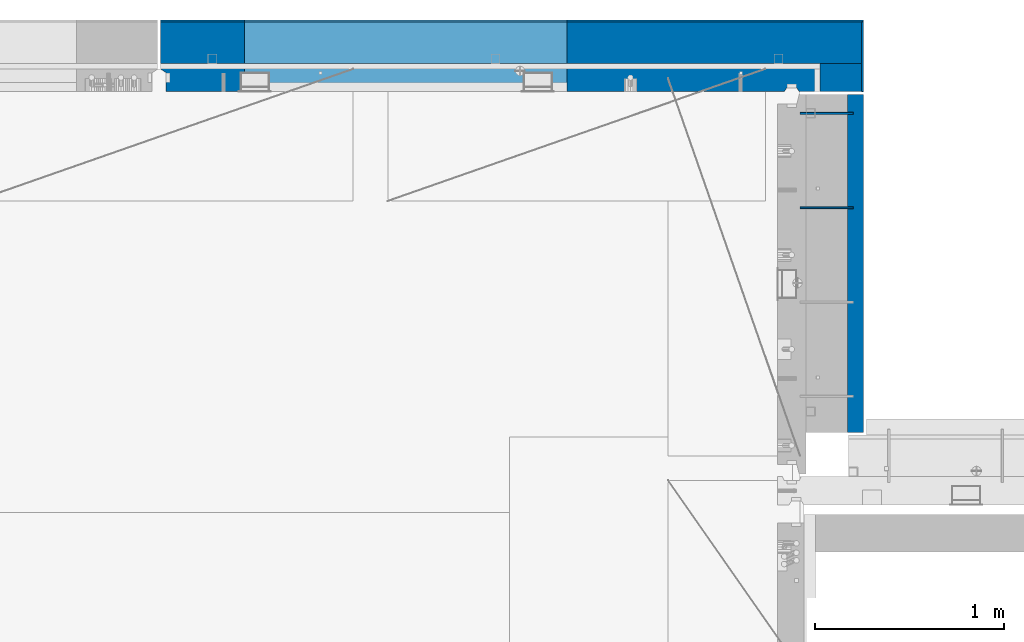
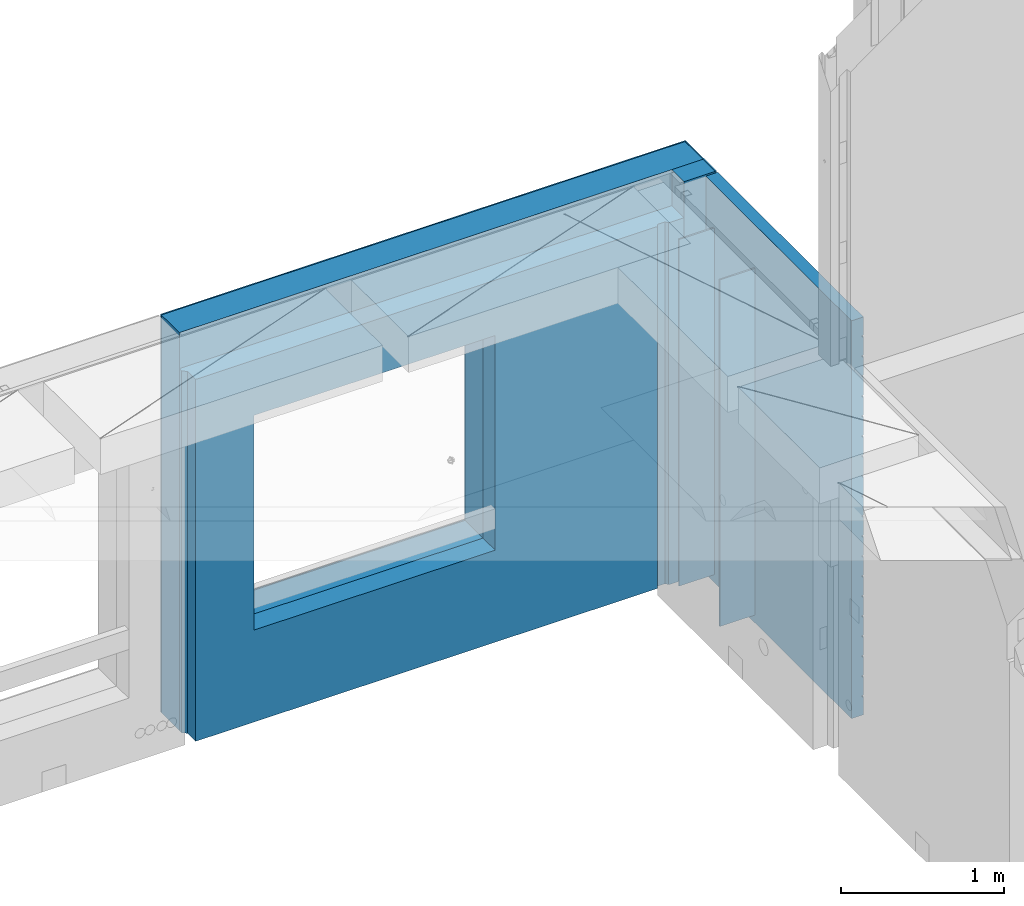
# One storey, part 239 of 352: 8 walls, 2 elements without a shape of their own.
"""IFC2X3 building model written with IfcOpenShell, lengths in millimetres."""

from ifc_helpers import new_model, si_unit, frame, origin_with_axes, place, context, subcontext, project, spatial, faceted_brep, material, type_object, element, aggregate, save


model = new_model("IFC2X3")

# Units and contexts
model_context = context("Model", 3, precision=1e-05, world=origin_with_axes())
body_context = subcontext(model_context, "Body", "Model", "MODEL_VIEW")
ifc_project = project(units=[si_unit("LENGTHUNIT", "METRE", prefix="MILLI"), si_unit("AREAUNIT", "SQUARE_METRE"), si_unit("VOLUMEUNIT", "CUBIC_METRE"), si_unit("MASSUNIT", "GRAM", prefix="KILO"), si_unit("TIMEUNIT", "SECOND"), si_unit("PLANEANGLEUNIT", "RADIAN"), si_unit("SOLIDANGLEUNIT", "STERADIAN"), si_unit("THERMODYNAMICTEMPERATUREUNIT", "DEGREE_CELSIUS"), si_unit("LUMINOUSINTENSITYUNIT", "LUMEN")], contexts=[model_context])

# Site, building, storey
site_placement = place(None, origin_with_axes())
site = spatial("IfcSite", under=ifc_project, at=site_placement, CompositionType="ELEMENT")
building_placement = place(site_placement, origin_with_axes())
building = spatial("IfcBuilding", under=site, at=building_placement, CompositionType="ELEMENT")
storey_placement = place(building_placement, origin_with_axes())
storey = spatial("IfcBuildingStorey", under=building, at=storey_placement, Name="6", CompositionType="ELEMENT", Elevation=0.0)

# Assembly, walls
assembly_1_placement = place(storey_placement, origin_with_axes())
assembly_1 = element("IfcElementAssembly", 1, at=assembly_1_placement, inside=storey, AssemblyPlace="NOTDEFINED", PredefinedType="REINFORCEMENT_UNIT")
ifc_material_1 = material(Name="Undefined")
wall_type_1 = type_object("IfcWallType", PredefinedType="NOTDEFINED")
wall_1_placement = place(assembly_1_placement, frame((17730.0, 22005.0, 98115.0), z_axis=(0.0, 0.0, 1.0), x_axis=(1.0, 0.0, 0.0)))
wall_1 = element("IfcWall", 2, at=wall_1_placement, type_object=wall_type_1, material=ifc_material_1, Name="(PD)", context=body_context, shape_type="Brep", body=[
    faceted_brep([(0.0, 5.0, -1300.0), (0.0, 5.0, 1300.0), (280.0, 5.0, 1300.0), (280.0, 5.0, -1300.0), (0.0, -5.0, 1300.0), (280.0, -5.0, 1300.0), (0.0, -5.0, -1300.0), (280.0, -5.0, -1300.0)], [[[0, 1, 2, 3]], [[1, 4, 5, 2]], [[4, 6, 7, 5]], [[6, 0, 3, 7]], [[5, 7, 3, 2]], [[6, 4, 1, 0]]]),
])
wall_2_placement = place(assembly_1_placement, frame((17730.0, 22505.0, 98115.0), z_axis=(0.0, 0.0, 1.0), x_axis=(1.0, 0.0, 0.0)))
wall_2 = element("IfcWall", 3, at=wall_2_placement, type_object=wall_type_1, material=ifc_material_1, Name="(PD)", context=body_context, shape_type="Brep", body=[
    faceted_brep([(0.0, 5.0, -1300.0), (0.0, 5.0, 1300.0), (280.0, 5.0, 1300.0), (280.0, 5.0, -1300.0), (0.0, -5.0, 1300.0), (280.0, -5.0, 1300.0), (0.0, -5.0, -1300.0), (280.0, -5.0, -1300.0)], [[[0, 1, 2, 3]], [[1, 4, 5, 2]], [[4, 6, 7, 5]], [[6, 0, 3, 7]], [[5, 7, 3, 2]], [[6, 4, 1, 0]]]),
])

assembly_2_placement = place(storey_placement, origin_with_axes())
assembly_2 = element("IfcElementAssembly", 4, at=assembly_2_placement, inside=storey, AssemblyPlace="NOTDEFINED", PredefinedType="REINFORCEMENT_UNIT")
ifc_material_2 = material()
wall_type_2 = type_object("IfcWallType", PredefinedType="NOTDEFINED")
wall_3_placement = place(assembly_2_placement, frame((17945.0, 22770.0, 98247.5), z_axis=(0.0, 0.0, 1.0), x_axis=(0.0, -1.0, 0.0)))
wall_3 = element("IfcWall", 5, at=wall_3_placement, type_object=wall_type_2, material=ifc_material_2, context=body_context, shape_type="Brep", body=[
    faceted_brep([(0.0, 110.0, -1492.5), (0.0, 110.0, 1492.5), (150.0, 110.0, 1492.5), (150.0, 110.0, -1492.5), (0.0, -110.0, 1492.5), (150.0, -110.0, 1492.5), (0.0, -110.0, -1492.5), (150.0, -110.0, -1492.5)], [[[0, 1, 2, 3]], [[1, 4, 5, 2]], [[4, 6, 7, 5]], [[6, 0, 3, 7]], [[5, 7, 3, 2]], [[6, 4, 1, 0]]]),
])
wall_4_placement = place(assembly_2_placement, frame((14340.0, 22880.0, 98247.5), z_axis=(0.0, 0.0, 1.0), x_axis=(1.0, 0.0, 0.0)))
wall_4 = element("IfcWall", 6, at=wall_4_placement, type_object=wall_type_2, material=ifc_material_2, context=body_context, shape_type="Brep", body=[
    faceted_brep([(0.0, -110.0, -1492.5), (0.0, 110.0, -1492.5), (3715.0, 110.0, -1492.5), (3715.0, -110.0, -1492.5), (0.0, -110.0, 1492.5), (0.0, 110.0, 1492.5), (3715.0, -110.0, 1492.5), (3715.0, 110.0, 1492.5), (444.999710731721, 110.0, -802.5), (2154.99971073172, 110.0, -802.5), (2154.99971073172, 110.0, 807.5), (444.999710731721, 110.0, 807.5), (444.999710731721, -110.0, -802.5), (444.999710731721, -110.0, 807.5), (2154.99971073172, -110.0, 807.5), (2154.99971073172, -110.0, -802.5)], [[[0, 1, 2, 3]], [[0, 4, 5, 1]], [[5, 4, 6, 7]], [[1, 5, 7, 2], [8, 9, 10, 11]], [[6, 3, 2, 7]], [[4, 0, 3, 6], [12, 13, 14, 15]], [[10, 14, 13, 11]], [[9, 15, 14, 10]], [[8, 12, 15, 9]], [[11, 13, 12, 8]]]),
])

# Wall
ifc_material_3 = material(Name="CONCRETE/C30/37")
wall_type_3 = type_object("IfcWallType", PredefinedType="NOTDEFINED")
wall_5_placement = place(assembly_1_placement, frame((18022.5, 22620.0, 98247.5), z_axis=(0.0, 0.0, 1.0), x_axis=(0.0, -1.0, 0.0)))
wall_5 = element("IfcWall", 7, at=wall_5_placement, type_object=wall_type_3, material=ifc_material_3, context=body_context, shape_type="Brep", body=[
    faceted_brep([(15.0, 42.5, 1342.99999994476), (15.0, 32.4999992506928, 1344.9999999992), (1805.0, 32.5, 1345.0), (1805.0, 42.5, 1343.0), (15.0, 32.4999991126933, 1355.00000040043), (1805.0, 32.5, 1355.0), (15.0, 42.5, 1356.99999988925), (1805.0, 42.5, 1357.0), (15.0, 42.5, 1206.99999988925), (1805.0, 42.5, 1207.0), (1805.0, 32.5, 1205.0), (15.0000000000009, 32.4999991126933, 1205.00000040043), (1805.0, 32.5, 1195.0), (15.0000000000009, 32.4999992506928, 1194.9999999992), (15.0, 42.5, 1192.99999994476), (1805.0, 42.5, 1193.0), (1805.0, 42.5, 1057.0), (15.0, 42.5, 1056.99999988925), (1805.0, 32.5, 1055.0), (15.0, 32.4999991126933, 1055.00000040043), (1805.0, 32.5, 1045.0), (15.0, 32.4999992506928, 1044.9999999992), (15.0, 42.5, 1042.99999994476), (1805.0, 42.5, 1043.0), (1805.0, 42.5, 907.0), (15.0, 42.5, 906.999999889245), (1805.0, 32.5, 905.0), (15.0, 32.4999991126933, 905.000000400425), (1805.0, 32.5, 895.0), (15.0, 32.4999992506928, 894.9999999992), (15.0, 42.5, 892.999999944761), (1805.0, 42.5, 893.0), (1805.0, 42.5, 757.0), (15.0, 42.5, 756.999999889245), (1805.0, 32.5, 755.0), (15.0, 32.4999991126933, 755.000000400425), (1805.0, 32.5, 745.0), (15.0, 32.4999992506928, 744.9999999992), (15.0, 42.5, 742.999999944761), (1805.0, 42.5, 743.0), (1805.0, 42.5, 607.0), (15.0, 42.5, 606.999999889245), (1805.0, 32.5, 605.0), (15.0, 32.4999991126933, 605.000000400425), (1805.0, 32.5, 595.0), (15.0, 32.4999992506928, 594.9999999992), (15.0, 42.5, 592.999999944761), (1805.0, 42.5, 593.0), (1805.0, 42.5, 457.0), (15.0, 42.5, 456.999999889245), (1805.0, 32.5, 455.0), (15.0, 32.4999991126933, 455.000000400425), (1805.0, 32.5, 445.0), (15.0, 32.4999992506928, 444.9999999992), (15.0, 42.5, 442.999999944761), (1805.0, 42.5, 443.0), (1805.0, 42.5, 307.0), (15.0, 42.5, 306.999999889245), (1805.0, 32.5, 305.0), (15.0, 32.4999991126933, 305.000000400425), (1805.0, 32.5, 295.0), (15.0, 32.4999992506928, 294.9999999992), (15.0, 42.5, 292.999999944761), (1805.0, 42.5, 293.0), (1805.0, 42.5, 157.0), (15.0, 42.5, 156.999999889245), (1805.0, 32.5, 155.0), (15.0000000000009, 32.4999991126933, 155.000000400425), (1805.0, 32.5, 145.0), (15.0000000000009, 32.4999992506928, 144.9999999992), (15.0, 42.5, 142.999999944761), (1805.0, 42.5, 143.0), (1805.0, 42.5, 7.0), (15.0, 42.5, 6.99999988924537), (1805.0, 32.5, 5.0), (14.9999999999991, 32.4999991126933, 5.00000040042505), (1805.0, 32.5, -5.0), (14.9999999999991, 32.4999992506928, -5.00000000080036), (15.0, 42.5, -7.00000005523907), (1805.0, 42.5, -7.0), (1805.0, 42.5, -143.0), (15.0, 42.5, -143.000000110755), (1805.0, 32.5, -145.0), (15.0000000000009, 32.4999991126933, -144.999999599575), (1805.0, 32.5, -155.0), (15.0000000000009, 32.4999992506928, -155.0000000008), (15.0, 42.5, -157.000000055239), (1805.0, 42.5, -157.0), (1805.0, 42.5, -293.0), (15.0, 42.5, -293.000000110755), (1805.0, 32.5, -295.0), (15.0, 32.4999991126933, -294.999999599575), (1805.0, 32.5, -305.0), (15.0, 32.4999992506928, -305.0000000008), (15.0, 42.5, -307.000000055239), (1805.0, 42.5, -307.0), (1805.0, 42.5, -443.0), (15.0, 42.5, -443.000000110755), (1805.0, 32.5, -445.0), (15.0000000000009, 32.4999991126933, -444.999999599575), (1805.0, 32.5, -455.0), (15.0000000000009, 32.4999992506928, -455.0000000008), (15.0, 42.5, -457.000000055239), (1805.0, 42.5, -457.0), (1805.0, 42.5, -593.0), (15.0, 42.5, -593.000000110755), (1805.0, 32.5, -595.0), (15.0, 32.4999991126933, -594.999999599575), (1805.0, 32.5, -605.0), (15.0, 32.4999992506928, -605.0000000008), (15.0, 42.5, -607.000000055239), (1805.0, 42.5, -607.0), (1805.0, 42.5, -743.0), (15.0, 42.5, -743.000000110755), (1805.0, 32.5, -745.0), (15.0, 32.4999991126933, -744.999999599575), (1805.0, 32.5, -755.0), (15.0, 32.4999992506928, -755.0000000008), (15.0, 42.5, -757.000000055239), (1805.0, 42.5, -757.0), (1805.0, 42.5, -893.0), (15.0, 42.5, -893.000000110755), (1805.0, 32.5, -895.0), (15.0000000000009, 32.4999991126933, -894.999999599575), (1805.0, 32.5, -905.0), (15.0000000000009, 32.4999992506928, -905.0000000008), (15.0, 42.5, -907.000000055239), (1805.0, 42.5, -907.0), (1805.0, 42.5, -1043.0), (15.0, 42.5, -1043.00000011075), (1805.0, 32.5, -1045.0), (15.0, 32.4999991126933, -1044.99999959957), (1805.0, 32.5, -1055.0), (15.0, 32.4999992506928, -1055.0000000008), (15.0, 42.5, -1057.00000005524), (1805.0, 42.5, -1057.0), (1805.0, 42.5, -1193.0), (15.0, 42.5, -1193.00000011075), (1805.0, 32.5, -1195.0), (15.0, 32.4999991126933, -1194.99999959957), (1805.0, 32.5, -1205.0), (15.0, 32.4999992506928, -1205.0000000008), (15.0, 42.5, -1207.00000005524), (1805.0, 42.5, -1207.0), (1805.0, 42.5, -1343.0), (15.0, 42.5, -1343.00000011075), (1805.0, 32.5, -1345.0), (15.0, 32.4999991126933, -1344.99999959957), (1805.0, 32.5, -1355.0), (15.0, 32.4999992506928, -1355.0000000008), (15.0, 42.5, -1357.00000005524), (1805.0, 42.5, -1357.0), (1805.0, 42.5, -1492.5), (15.0, 42.5, -1492.5), (15.0, -42.5, -1492.5), (1805.0, -42.5, -1492.5), (15.0, -42.5, 1492.5), (1805.0, -42.5, 1492.5), (15.0, 42.5, 1492.5), (1805.0, 42.5, 1492.5)], [[[0, 1, 2, 3]], [[4, 5, 2, 1]], [[6, 7, 5, 4]], [[8, 9, 10, 11]], [[11, 10, 12, 13]], [[14, 13, 12, 15]], [[16, 17, 14, 15]], [[17, 16, 18, 19]], [[19, 18, 20, 21]], [[22, 21, 20, 23]], [[24, 25, 22, 23]], [[25, 24, 26, 27]], [[27, 26, 28, 29]], [[30, 29, 28, 31]], [[32, 33, 30, 31]], [[33, 32, 34, 35]], [[35, 34, 36, 37]], [[38, 37, 36, 39]], [[40, 41, 38, 39]], [[41, 40, 42, 43]], [[43, 42, 44, 45]], [[46, 45, 44, 47]], [[48, 49, 46, 47]], [[49, 48, 50, 51]], [[51, 50, 52, 53]], [[54, 53, 52, 55]], [[56, 57, 54, 55]], [[57, 56, 58, 59]], [[59, 58, 60, 61]], [[62, 61, 60, 63]], [[64, 65, 62, 63]], [[65, 64, 66, 67]], [[67, 66, 68, 69]], [[70, 69, 68, 71]], [[72, 73, 70, 71]], [[73, 72, 74, 75]], [[75, 74, 76, 77]], [[78, 77, 76, 79]], [[80, 81, 78, 79]], [[81, 80, 82, 83]], [[83, 82, 84, 85]], [[86, 85, 84, 87]], [[88, 89, 86, 87]], [[89, 88, 90, 91]], [[91, 90, 92, 93]], [[94, 93, 92, 95]], [[96, 97, 94, 95]], [[97, 96, 98, 99]], [[99, 98, 100, 101]], [[102, 101, 100, 103]], [[104, 105, 102, 103]], [[105, 104, 106, 107]], [[107, 106, 108, 109]], [[110, 109, 108, 111]], [[112, 113, 110, 111]], [[113, 112, 114, 115]], [[115, 114, 116, 117]], [[118, 117, 116, 119]], [[120, 121, 118, 119]], [[121, 120, 122, 123]], [[123, 122, 124, 125]], [[126, 125, 124, 127]], [[128, 129, 126, 127]], [[129, 128, 130, 131]], [[131, 130, 132, 133]], [[134, 133, 132, 135]], [[136, 137, 134, 135]], [[137, 136, 138, 139]], [[139, 138, 140, 141]], [[142, 141, 140, 143]], [[144, 145, 142, 143]], [[145, 144, 146, 147]], [[147, 146, 148, 149]], [[150, 149, 148, 151]], [[152, 153, 150, 151]], [[154, 153, 152, 155]], [[156, 154, 155, 157]], [[158, 156, 157, 159]], [[1, 0, 8, 11, 13, 14, 17, 19, 21, 22, 25, 27, 29, 30, 33, 35, 37, 38, 41, 43, 45, 46, 49, 51, 53, 54, 57, 59, 61, 62, 65, 67, 69, 70, 73, 75, 77, 78, 81, 83, 85, 86, 89, 91, 93, 94, 97, 99, 101, 102, 105, 107, 109, 110, 113, 115, 117, 118, 121, 123, 125, 126, 129, 131, 133, 134, 137, 139, 141, 142, 145, 147, 149, 150, 153, 154, 156, 158, 6, 4]], [[9, 8, 0, 3]], [[159, 157, 155, 152, 151, 148, 146, 144, 143, 140, 138, 136, 135, 132, 130, 128, 127, 124, 122, 120, 119, 116, 114, 112, 111, 108, 106, 104, 103, 100, 98, 96, 95, 92, 90, 88, 87, 84, 82, 80, 79, 76, 74, 72, 71, 68, 66, 64, 63, 60, 58, 56, 55, 52, 50, 48, 47, 44, 42, 40, 39, 36, 34, 32, 31, 28, 26, 24, 23, 20, 18, 16, 15, 12, 10, 9, 3, 2, 5, 7]], [[158, 159, 7, 6]]]),
])

aggregate(assembly_1, [wall_1, wall_2, wall_5])

ifc_material_4 = material(Name="CONCRETE/C25/30")
wall_type_4 = type_object("IfcWallType", PredefinedType="NOTDEFINED")
wall_6_placement = place(assembly_2_placement, frame((14340.0, 22695.0, 98112.5), z_axis=(0.0, 0.0, 1.0), x_axis=(1.0, 0.0, 0.0)))
wall_6 = element("IfcWall", 8, at=wall_6_placement, type_object=wall_type_4, material=ifc_material_4, context=body_context, shape_type="Brep", body=[
    faceted_brep([(444.999710731721, 75.0, 942.5), (444.999710731721, -75.0, 942.5), (444.999710731721, -75.0, -667.5), (444.999710731721, 75.0, -667.5), (2154.99971073172, -75.0, -667.5), (2154.99971073172, 75.0, -667.5), (2154.99971073172, -75.0, 942.5), (2154.99971073172, 75.0, 942.5), (3305.0, -75.0, 1357.5), (3318.00000041054, -54.9999993903439, 1357.5), (3372.00000031511, -54.9999994175341, 1357.5), (3385.00000278453, -75.0000022791319, 1357.5), (3495.0, -75.0, 1357.5), (3495.0, 75.0, 1357.5), (0.0, 75.0, 1357.5), (0.0, 45.0, 1357.5), (30.0000010550393, 24.9999970131248, 1357.5), (30.0000016637459, -75.0, 1357.5), (3305.0, -75.0, -1357.5), (3318.00000041054, -54.9999993903439, -1357.5), (3372.00000031511, -54.9999994175341, -1357.5), (3385.00000278453, -75.0, -1357.5), (3495.0, -75.0, -1357.5), (3495.0, 75.0, -1357.5), (0.0, 75.0, -1357.5), (0.0, 45.0, -1357.5), (30.0000010550393, 24.9999970131248, -1357.49999999999), (30.0000016637459, -75.0, -1357.5)], [[[0, 1, 2, 3]], [[3, 2, 4, 5]], [[5, 4, 6, 7]], [[7, 6, 1, 0]], [[8, 9, 10, 11, 12, 13, 14, 15, 16, 17]], [[8, 18, 19, 9]], [[9, 19, 20, 10]], [[11, 10, 20, 21]], [[22, 12, 11, 21]], [[12, 22, 23, 13]], [[24, 14, 13, 23], [3, 5, 7, 0]], [[14, 24, 25, 15]], [[15, 25, 26, 16]], [[24, 23, 22, 21, 20, 19, 18, 27, 26, 25]], [[16, 26, 27, 17]], [[18, 8, 17, 27], [2, 1, 6, 4]]]),
])

wall_type_5 = type_object("IfcWallType", PredefinedType="NOTDEFINED")
wall_7_placement = place(assembly_2_placement, frame((18060.0, 22990.0, 98247.5), z_axis=(0.0, 0.0, 1.0), x_axis=(0.0, -1.0, 0.0)))
wall_7 = element("IfcWall", 9, at=wall_7_placement, type_object=wall_type_5, material=ifc_material_3, context=body_context, shape_type="Brep", body=[
    faceted_brep([(0.0, 5.0, -1492.5), (0.0, 5.0, 1492.5), (370.0, 5.0, 1492.5), (370.0, 5.0, -1492.5), (0.0, -5.0, 1492.5), (370.0, -5.0, 1492.5), (0.0, -5.0, -1492.5), (370.0, -5.0, -1492.5)], [[[0, 1, 2, 3]], [[1, 4, 5, 2]], [[4, 6, 7, 5]], [[6, 0, 3, 7]], [[5, 7, 3, 2]], [[6, 4, 1, 0]]]),
])

wall_8_placement = place(assembly_2_placement, frame((14340.0, 22995.0, 98247.5), z_axis=(0.0, 0.0, 1.0), x_axis=(1.0, 0.0, 0.0)))
wall_8 = element("IfcWall", 10, at=wall_8_placement, type_object=wall_type_5, material=ifc_material_3, context=body_context, shape_type="Brep", body=[
    faceted_brep([(0.0, -5.0, -1492.5), (0.0, 5.0, -1492.5), (3725.0, 5.0, -1492.5), (3725.0, -5.0, -1492.5), (0.0, -5.0, 1492.5), (0.0, 5.0, 1492.5), (3725.0, -5.0, 1492.5), (3725.0, 5.0, 1492.5), (444.999710731721, 5.0, -802.5), (2154.99971073172, 5.0, -802.5), (2154.99971073172, 5.0, 807.5), (444.999710731721, 5.0, 807.5), (444.999710731721, -5.0, -802.5), (444.999710731721, -5.0, 807.5), (2154.99971073172, -5.0, 807.5), (2154.99971073172, -5.0, -802.5)], [[[0, 1, 2, 3]], [[0, 4, 5, 1]], [[5, 4, 6, 7]], [[1, 5, 7, 2], [8, 9, 10, 11]], [[6, 3, 2, 7]], [[4, 0, 3, 6], [12, 13, 14, 15]], [[10, 14, 13, 11]], [[9, 15, 14, 10]], [[8, 12, 15, 9]], [[11, 13, 12, 8]]]),
])

aggregate(assembly_2, [wall_7, wall_3, wall_4, wall_8, wall_6])

save(model, "model.ifc")
